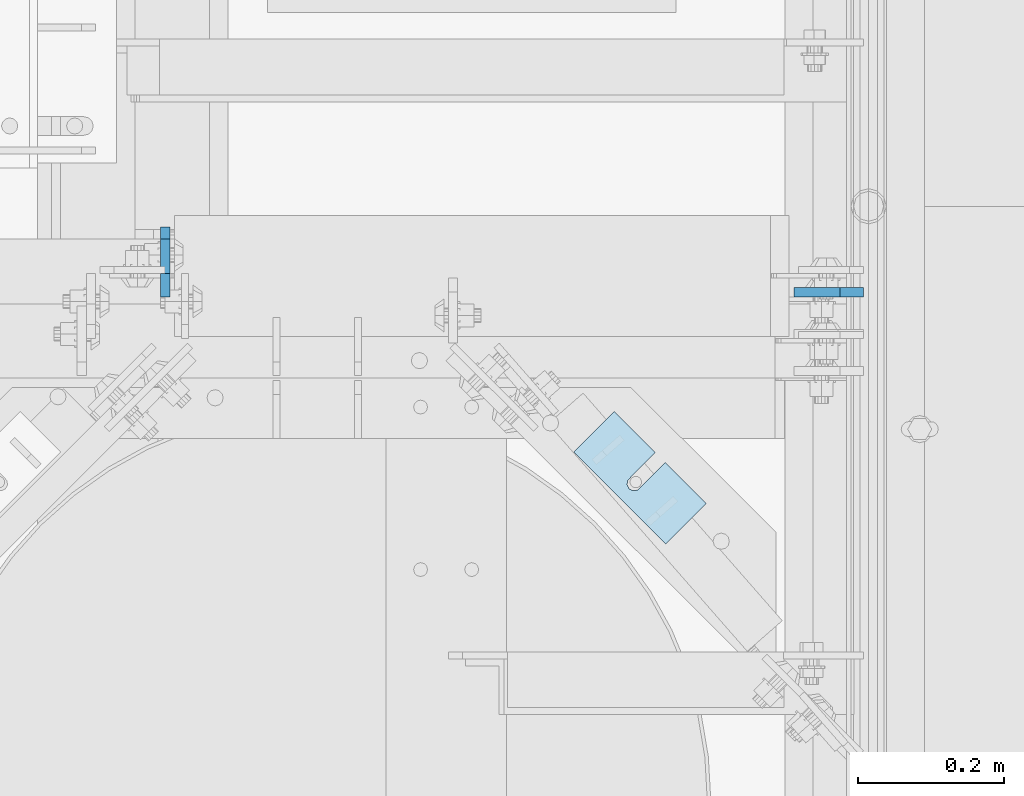
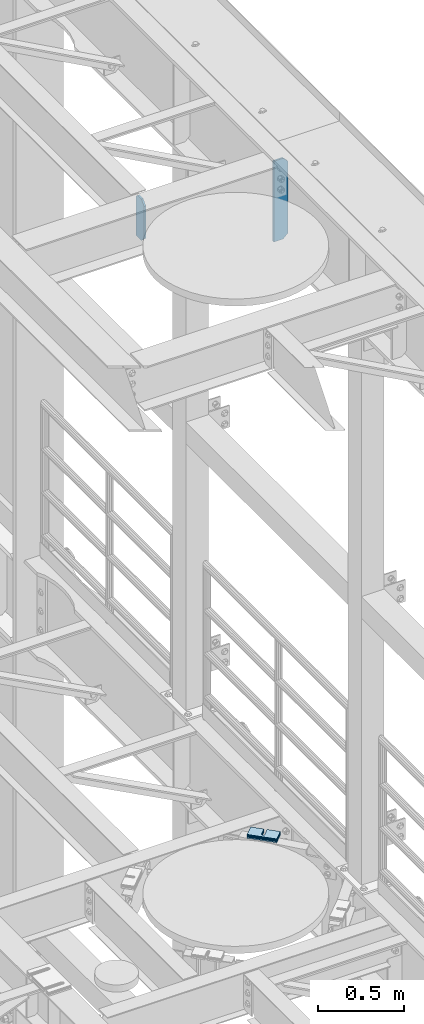
# One storey, part 1662 of 1876: 8 plates, 8 elements without a shape of their own.
"""IFC2X3 building model written with IfcOpenShell, lengths in millimetres."""

from ifc_helpers import new_model, si_unit, frame, origin_with_axes, place, context, subcontext, project, spatial, faceted_brep, material, type_object, element, aggregate, save


model = new_model("IFC2X3")

# Units and contexts
model_context = context("Model", 3, precision=1e-05, world=origin_with_axes())
body_context = subcontext(model_context, "Body", "Model", "MODEL_VIEW")
ifc_project = project(units=[si_unit("LENGTHUNIT", "METRE", prefix="MILLI"), si_unit("AREAUNIT", "SQUARE_METRE"), si_unit("VOLUMEUNIT", "CUBIC_METRE"), si_unit("MASSUNIT", "GRAM", prefix="KILO"), si_unit("TIMEUNIT", "SECOND"), si_unit("PLANEANGLEUNIT", "RADIAN"), si_unit("SOLIDANGLEUNIT", "STERADIAN"), si_unit("THERMODYNAMICTEMPERATUREUNIT", "DEGREE_CELSIUS"), si_unit("LUMINOUSINTENSITYUNIT", "LUMEN")], contexts=[model_context])

# Site, building, storey
site_placement = place(None, origin_with_axes())
site = spatial("IfcSite", under=ifc_project, at=site_placement, CompositionType="ELEMENT")
building_placement = place(site_placement, origin_with_axes())
building = spatial("IfcBuilding", under=site, at=building_placement, Name="Undefined", CompositionType="ELEMENT")
storey_placement = place(building_placement, origin_with_axes())
storey = spatial("IfcBuildingStorey", under=building, at=storey_placement, Name="Undefined", CompositionType="ELEMENT", Elevation=0.0)

# Assembly, plate
assembly_1_placement = place(storey_placement, origin_with_axes())
assembly_1 = element("IfcElementAssembly", 1, at=assembly_1_placement, inside=storey, Name="BEAM", AssemblyPlace="NOTDEFINED", PredefinedType="RIGID_FRAME")
ifc_material = material(Name="STEEL/A36")
plate_type_1 = type_object("IfcPlateType", PredefinedType="NOTDEFINED")
plate_1_placement = place(assembly_1_placement, frame((6657.97499990463, 4448.17420043945, 22255.1625), z_axis=(0.0, 0.0, 1.0), x_axis=(0.0, 1.0, 0.0)))
plate_1 = element("IfcPlate", 2, at=plate_1_placement, type_object=plate_type_1, material=ifc_material, Name="PLATE", context=body_context, shape_type="Brep", body=[
    faceted_brep([(0.0, -6.35000000000036, 258.762512207031), (31.75, -6.35000000000036, 290.512512207031), (31.75, 6.35000000000036, 290.512512207031), (0.0, 6.35000000000036, 258.762512207031), (0.0, -6.34999999999991, 31.75), (0.0, 6.34999999999991, 31.75), (31.75, -6.34999999999991, 0.0), (31.75, 6.34999999999991, 0.0), (95.25, -6.35000000000036, 0.0), (95.25, 6.35000000000036, 0.0), (95.25, -6.35000000000036, 274.637511908913), (79.3749874887271, -6.35000000000036, 290.512512207031), (79.3749874887271, 6.35000000000036, 290.512512207031), (95.25, 6.35000000000036, 274.637511908913)], [[[0, 1, 2, 3]], [[4, 0, 3, 5]], [[6, 4, 5, 7]], [[8, 6, 7, 9]], [[1, 0, 4, 6, 8, 10, 11]], [[2, 1, 11, 12]], [[9, 7, 5, 3, 2, 12, 13]], [[8, 9, 13, 10]], [[12, 11, 10, 13]]]),
])
aggregate(assembly_1, [plate_1])

assembly_2_placement = place(storey_placement, origin_with_axes())
assembly_2 = element("IfcElementAssembly", 3, at=assembly_2_placement, inside=storey, Name="BEAM", AssemblyPlace="NOTDEFINED", PredefinedType="RIGID_FRAME")
plate_2_placement = place(assembly_2_placement, frame((7612.85625, 4454.52420053482, 21959.8875), z_axis=(0.0, 0.0, 1.0), x_axis=(-1.0, 0.0, 0.0)))
plate_2 = element("IfcPlate", 4, at=plate_2_placement, type_object=plate_type_1, material=ifc_material, Name="PLATE", context=body_context, shape_type="Brep", body=[
    faceted_brep([(0.0, -6.34999999999991, 31.75), (0.0, -6.35000000000036, 538.162475585938), (0.0, 6.35000000000036, 538.162475585938), (0.0, 6.34999999999991, 31.75), (31.75, -6.35000000000036, 569.912475585938), (31.75, 6.35000000000036, 569.912475585938), (95.25, -6.35000000000036, 569.912475585938), (95.25, 6.35000000000036, 569.912475585938), (95.25, -6.35000000000036, 0.0), (95.25, 6.35000000000036, 0.0), (31.75, -6.34999999999991, 0.0), (31.75, 6.34999999999991, 0.0)], [[[0, 1, 2, 3]], [[1, 4, 5, 2]], [[4, 6, 7, 5]], [[6, 8, 9, 7]], [[8, 10, 11, 9]], [[10, 0, 3, 11]], [[5, 7, 9, 11, 3, 2]], [[10, 8, 6, 4, 1, 0]]]),
])
aggregate(assembly_2, [plate_2])

assembly_3_placement = place(storey_placement, origin_with_axes())
assembly_3 = element("IfcElementAssembly", 5, at=assembly_3_placement, inside=storey, Name="SHIM PLATE", AssemblyPlace="NOTDEFINED", PredefinedType="RIGID_FRAME")
plate_type_2 = type_object("IfcPlateType", PredefinedType="NOTDEFINED")
plate_3_placement = place(assembly_3_placement, frame((7397.85899402552, 4165.55524499807, 18009.3925), z_axis=(-0.707106066686189, -0.707107495686184, 0.0), x_axis=(-0.707107495686184, 0.707106066686189, 0.0)))
plate_3 = element("IfcPlate", 6, at=plate_3_placement, type_object=plate_type_2, material=ifc_material, Name="SHIM PLATE", context=body_context, shape_type="Brep", body=[
    faceted_brep([(79.3755953647978, -0.793499999999767, -3.63797880709171e-12), (79.3755953647978, 0.793499999999767, -3.63797880709171e-12), (79.3049756952778, 0.793499999999767, 47.6675290359176), (79.3049756952778, -0.793499999999767, 47.6675290359176), (79.4487723981229, 0.793499999999767, 53.7022829617508), (79.4487723981229, -0.793499999999767, 53.7022829617508), (83.063498120483, 0.793499999999767, 58.5368140030459), (83.063498120483, -0.793499999999767, 58.5368140030459), (88.8111609071966, 0.793499999999767, 60.3816188510955), (88.8111609071966, -0.793499999999767, 60.3816188510955), (94.5642614235203, 0.793499999999767, 58.5538423641483), (94.5642614235203, -0.793499999999767, 58.5538423641483), (98.3549540510812, -0.793499999999767, 47.6957349820686), (98.3549540510812, 0.793499999999767, 47.6957349820686), (98.4255737206086, 0.793499999999767, -5.00222085975111e-12), (98.4255737206086, -0.793499999999767, -5.00222085975111e-12), (98.1932875572447, -0.793499999999767, 53.7300366303029), (98.1932875572447, 0.793499999999767, 53.7300366303029), (9.09494701772928e-13, -0.793499999999767, 0.0), (7.93202807471971e-05, -0.793499999999767, 78.4900512695085), (7.93202807471971e-05, 0.793499999999767, 78.4900512695085), (9.09494701772928e-13, 0.793499999999767, 0.0), (177.801101684615, -0.793499999999767, 78.4900512695531), (177.801101684615, 0.793499999999767, 78.4900512695531), (177.801147461002, -0.793499999999767, -8.64019966684282e-12), (177.801147461002, 0.793499999999767, -8.64019966684282e-12)], [[[0, 1, 2, 3]], [[3, 2, 4, 5]], [[5, 4, 6, 7]], [[7, 6, 8, 9]], [[9, 8, 10, 11]], [[12, 13, 14, 15]], [[16, 17, 13, 12]], [[11, 10, 17, 16]], [[18, 19, 20, 21]], [[19, 22, 23, 20]], [[22, 24, 25, 23]], [[25, 24, 15, 14]], [[8, 6, 4, 2, 1, 21, 20, 23, 25, 14, 13, 17, 10]], [[18, 21, 1, 0]], [[15, 24, 22, 19, 18, 0, 3, 5, 7, 9, 11, 16, 12]]]),
])
aggregate(assembly_3, [plate_3])

assembly_4_placement = place(storey_placement, origin_with_axes())
assembly_4 = element("IfcElementAssembly", 7, at=assembly_4_placement, inside=storey, Name="SHIM PLATE", AssemblyPlace="NOTDEFINED", PredefinedType="RIGID_FRAME")
plate_type_3 = type_object("IfcPlateType", PredefinedType="NOTDEFINED")
plate_4_placement = place(assembly_4_placement, frame((7397.85899402552, 4165.55524499807, 18007.0115), z_axis=(-0.707106066686189, -0.707107495686184, 0.0), x_axis=(-0.707107495686184, 0.707106066686189, 0.0)))
plate_4 = element("IfcPlate", 8, at=plate_4_placement, type_object=plate_type_3, material=ifc_material, Name="SHIM PLATE", context=body_context, shape_type="Brep", body=[
    faceted_brep([(79.3755953647988, -1.58750000000146, -3.18323145620525e-12), (79.3755953647988, 1.58750000000146, -3.18323145620525e-12), (79.3049756952778, 1.58750000000146, 47.6675290359181), (79.3049756952778, -1.58750000000146, 47.6675290359181), (79.4487723981229, 1.58750000000146, 53.7022829617513), (79.4487723981229, -1.58750000000146, 53.7022829617513), (83.0634981204839, 1.58750000000146, 58.5368140030464), (83.0634981204839, -1.58750000000146, 58.5368140030464), (88.8111609071975, 1.58750000000146, 60.3816188510959), (88.8111609071975, -1.58750000000146, 60.3816188510959), (94.5642614235212, 1.58750000000146, 58.5538423641487), (94.5642614235212, -1.58750000000146, 58.5538423641487), (98.3549540510821, -1.58750000000146, 47.6957349820691), (98.3549540510821, 1.58750000000146, 47.6957349820691), (98.4255737206086, 1.58750000000146, -3.63797880709171e-12), (98.4255737206086, -1.58750000000146, -3.63797880709171e-12), (98.1932875572456, -1.58750000000146, 53.7300366303034), (98.1932875572456, 1.58750000000146, 53.7300366303034), (9.09494701772928e-13, -1.58750000000146, 4.54747350886464e-13), (7.93202807471971e-05, -1.58750000000146, 78.490051269509), (7.93202807471971e-05, 1.58750000000146, 78.490051269509), (9.09494701772928e-13, 1.58750000000146, 4.54747350886464e-13), (177.801101684615, -1.58750000000146, 78.4900512695535), (177.801101684615, 1.58750000000146, 78.4900512695535), (177.801147461002, -1.58750000000146, -8.18545231595635e-12), (177.801147461002, 1.58750000000146, -8.18545231595635e-12)], [[[0, 1, 2, 3]], [[3, 2, 4, 5]], [[5, 4, 6, 7]], [[7, 6, 8, 9]], [[9, 8, 10, 11]], [[12, 13, 14, 15]], [[16, 17, 13, 12]], [[11, 10, 17, 16]], [[18, 19, 20, 21]], [[19, 22, 23, 20]], [[22, 24, 25, 23]], [[25, 24, 15, 14]], [[8, 6, 4, 2, 1, 21, 20, 23, 25, 14, 13, 17, 10]], [[18, 21, 1, 0]], [[15, 24, 22, 19, 18, 0, 3, 5, 7, 9, 11, 16, 12]]]),
])
aggregate(assembly_4, [plate_4])

assembly_5_placement = place(storey_placement, origin_with_axes())
assembly_5 = element("IfcElementAssembly", 9, at=assembly_5_placement, inside=storey, Name="SHIM PLATE", AssemblyPlace="NOTDEFINED", PredefinedType="RIGID_FRAME")
plate_5_placement = place(assembly_5_placement, frame((7397.85899402552, 4165.55524499807, 18003.8365), z_axis=(-0.707106066686189, -0.707107495686184, 0.0), x_axis=(-0.707107495686184, 0.707106066686189, 0.0)))
plate_5 = element("IfcPlate", 10, at=plate_5_placement, type_object=plate_type_3, material=ifc_material, Name="SHIM PLATE", context=body_context, shape_type="Brep", body=[
    faceted_brep([(79.3755953647988, -1.58750000000146, -3.18323145620525e-12), (79.3755953647988, 1.58750000000146, -3.18323145620525e-12), (79.3049756952778, 1.58750000000146, 47.6675290359181), (79.3049756952778, -1.58750000000146, 47.6675290359181), (79.4487723981229, 1.58750000000146, 53.7022829617513), (79.4487723981229, -1.58750000000146, 53.7022829617513), (83.0634981204839, 1.58750000000146, 58.5368140030464), (83.0634981204839, -1.58750000000146, 58.5368140030464), (88.8111609071975, 1.58750000000146, 60.3816188510959), (88.8111609071975, -1.58750000000146, 60.3816188510959), (94.5642614235212, 1.58750000000146, 58.5538423641487), (94.5642614235212, -1.58750000000146, 58.5538423641487), (98.3549540510821, -1.58750000000146, 47.6957349820691), (98.3549540510821, 1.58750000000146, 47.6957349820691), (98.4255737206086, 1.58750000000146, -3.63797880709171e-12), (98.4255737206086, -1.58750000000146, -3.63797880709171e-12), (98.1932875572456, -1.58750000000146, 53.7300366303034), (98.1932875572456, 1.58750000000146, 53.7300366303034), (9.09494701772928e-13, -1.58750000000146, 4.54747350886464e-13), (7.93202807471971e-05, -1.58750000000146, 78.490051269509), (7.93202807471971e-05, 1.58750000000146, 78.490051269509), (9.09494701772928e-13, 1.58750000000146, 4.54747350886464e-13), (177.801101684615, -1.58750000000146, 78.4900512695535), (177.801101684615, 1.58750000000146, 78.4900512695535), (177.801147461002, -1.58750000000146, -8.18545231595635e-12), (177.801147461002, 1.58750000000146, -8.18545231595635e-12)], [[[0, 1, 2, 3]], [[3, 2, 4, 5]], [[5, 4, 6, 7]], [[7, 6, 8, 9]], [[9, 8, 10, 11]], [[12, 13, 14, 15]], [[16, 17, 13, 12]], [[11, 10, 17, 16]], [[18, 19, 20, 21]], [[19, 22, 23, 20]], [[22, 24, 25, 23]], [[25, 24, 15, 14]], [[8, 6, 4, 2, 1, 21, 20, 23, 25, 14, 13, 17, 10]], [[18, 21, 1, 0]], [[15, 24, 22, 19, 18, 0, 3, 5, 7, 9, 11, 16, 12]]]),
])
aggregate(assembly_5, [plate_5])

assembly_6_placement = place(storey_placement, origin_with_axes())
assembly_6 = element("IfcElementAssembly", 11, at=assembly_6_placement, inside=storey, Name="SHIM PLATE", AssemblyPlace="NOTDEFINED", PredefinedType="RIGID_FRAME")
plate_type_4 = type_object("IfcPlateType", PredefinedType="NOTDEFINED")
plate_6_placement = place(assembly_6_placement, frame((7397.85899402552, 4165.55524499807, 17999.868), z_axis=(-0.707106066686189, -0.707107495686184, 0.0), x_axis=(-0.707107495686184, 0.707106066686189, 0.0)))
plate_6 = element("IfcPlate", 12, at=plate_6_placement, type_object=plate_type_4, material=ifc_material, Name="SHIM PLATE", context=body_context, shape_type="Brep", body=[
    faceted_brep([(79.3755953647969, -2.38100000000122, -3.18323145620525e-12), (79.3755953647969, 2.38100000000122, -3.18323145620525e-12), (79.3049756952778, 2.38100000000122, 47.6675290359181), (79.3049756952778, -2.38100000000122, 47.6675290359181), (79.4487723981229, 2.38100000000122, 53.7022829617513), (79.4487723981229, -2.38100000000122, 53.7022829617513), (83.063498120483, 2.38100000000122, 58.5368140030464), (83.063498120483, -2.38100000000122, 58.5368140030464), (88.8111609071966, 2.38100000000122, 60.3816188510959), (88.8111609071966, -2.38100000000122, 60.3816188510959), (94.5642614235203, 2.38100000000122, 58.5538423641487), (94.5642614235203, -2.38100000000122, 58.5538423641487), (98.3549540510821, -2.38100000000122, 47.6957349820691), (98.3549540510821, 2.38100000000122, 47.6957349820691), (98.4255737206086, 2.38100000000122, -4.54747350886464e-12), (98.4255737206086, -2.38100000000122, -4.54747350886464e-12), (98.1932875572447, -2.38100000000122, 53.7300366303034), (98.1932875572447, 2.38100000000122, 53.7300366303034), (0.0, -2.38100000000122, 4.54747350886464e-13), (7.93202807471971e-05, -2.38100000000122, 78.4900512695094), (7.93202807471971e-05, 2.38100000000122, 78.4900512695094), (0.0, 2.38100000000122, 4.54747350886464e-13), (177.801101684615, -2.38100000000122, 78.4900512695526), (177.801101684615, 2.38100000000122, 78.4900512695526), (177.801147461, -2.38100000000122, -7.73070496506989e-12), (177.801147461, 2.38100000000122, -7.73070496506989e-12)], [[[0, 1, 2, 3]], [[3, 2, 4, 5]], [[5, 4, 6, 7]], [[7, 6, 8, 9]], [[9, 8, 10, 11]], [[12, 13, 14, 15]], [[16, 17, 13, 12]], [[11, 10, 17, 16]], [[18, 19, 20, 21]], [[19, 22, 23, 20]], [[22, 24, 25, 23]], [[25, 24, 15, 14]], [[8, 6, 4, 2, 1, 21, 20, 23, 25, 14, 13, 17, 10]], [[18, 21, 1, 0]], [[15, 24, 22, 19, 18, 0, 3, 5, 7, 9, 11, 16, 12]]]),
])
aggregate(assembly_6, [plate_6])

assembly_7_placement = place(storey_placement, origin_with_axes())
assembly_7 = element("IfcElementAssembly", 13, at=assembly_7_placement, inside=storey, Name="SHIM PLATE", AssemblyPlace="NOTDEFINED", PredefinedType="RIGID_FRAME")
plate_7_placement = place(assembly_7_placement, frame((7397.85899402552, 4165.55524499807, 17995.106), z_axis=(-0.707106066686189, -0.707107495686184, 0.0), x_axis=(-0.707107495686184, 0.707106066686189, 0.0)))
plate_7 = element("IfcPlate", 14, at=plate_7_placement, type_object=plate_type_4, material=ifc_material, Name="SHIM PLATE", context=body_context, shape_type="Brep", body=[
    faceted_brep([(79.3755953647969, -2.38100000000122, -3.18323145620525e-12), (79.3755953647969, 2.38100000000122, -3.18323145620525e-12), (79.3049756952778, 2.38100000000122, 47.6675290359181), (79.3049756952778, -2.38100000000122, 47.6675290359181), (79.4487723981229, 2.38100000000122, 53.7022829617513), (79.4487723981229, -2.38100000000122, 53.7022829617513), (83.063498120483, 2.38100000000122, 58.5368140030464), (83.063498120483, -2.38100000000122, 58.5368140030464), (88.8111609071966, 2.38100000000122, 60.3816188510959), (88.8111609071966, -2.38100000000122, 60.3816188510959), (94.5642614235203, 2.38100000000122, 58.5538423641487), (94.5642614235203, -2.38100000000122, 58.5538423641487), (98.3549540510821, -2.38100000000122, 47.6957349820691), (98.3549540510821, 2.38100000000122, 47.6957349820691), (98.4255737206086, 2.38100000000122, -4.54747350886464e-12), (98.4255737206086, -2.38100000000122, -4.54747350886464e-12), (98.1932875572447, -2.38100000000122, 53.7300366303034), (98.1932875572447, 2.38100000000122, 53.7300366303034), (0.0, -2.38100000000122, 4.54747350886464e-13), (7.93202807471971e-05, -2.38100000000122, 78.4900512695094), (7.93202807471971e-05, 2.38100000000122, 78.4900512695094), (0.0, 2.38100000000122, 4.54747350886464e-13), (177.801101684615, -2.38100000000122, 78.4900512695526), (177.801101684615, 2.38100000000122, 78.4900512695526), (177.801147461, -2.38100000000122, -7.73070496506989e-12), (177.801147461, 2.38100000000122, -7.73070496506989e-12)], [[[0, 1, 2, 3]], [[3, 2, 4, 5]], [[5, 4, 6, 7]], [[7, 6, 8, 9]], [[9, 8, 10, 11]], [[12, 13, 14, 15]], [[16, 17, 13, 12]], [[11, 10, 17, 16]], [[18, 19, 20, 21]], [[19, 22, 23, 20]], [[22, 24, 25, 23]], [[25, 24, 15, 14]], [[8, 6, 4, 2, 1, 21, 20, 23, 25, 14, 13, 17, 10]], [[18, 21, 1, 0]], [[15, 24, 22, 19, 18, 0, 3, 5, 7, 9, 11, 16, 12]]]),
])
aggregate(assembly_7, [plate_7])

assembly_8_placement = place(storey_placement, origin_with_axes())
assembly_8 = element("IfcElementAssembly", 15, at=assembly_8_placement, inside=storey, Name="SHIM PLATE", AssemblyPlace="NOTDEFINED", PredefinedType="RIGID_FRAME")
plate_type_5 = type_object("IfcPlateType", PredefinedType="NOTDEFINED")
plate_8_placement = place(assembly_8_placement, frame((7397.85899402552, 4165.55524499807, 17987.9625), z_axis=(-0.707106066686189, -0.707107495686184, 0.0), x_axis=(-0.707107495686184, 0.707106066686189, 0.0)))
plate_8 = element("IfcPlate", 16, at=plate_8_placement, type_object=plate_type_5, material=ifc_material, Name="SHIM PLATE", context=body_context, shape_type="Brep", body=[
    faceted_brep([(79.3755953647978, -4.76250000000073, -2.27373675443232e-12), (79.3755953647978, 4.76250000000073, -2.27373675443232e-12), (79.3049756952787, 4.76250000000073, 47.6675290359171), (79.3049756952787, -4.76250000000073, 47.6675290359171), (79.4487723981238, 4.76250000000073, 53.7022829617517), (79.4487723981238, -4.76250000000073, 53.7022829617517), (83.0634981204839, 4.76250000000073, 58.5368140030459), (83.0634981204839, -4.76250000000073, 58.5368140030459), (88.8111609071975, 4.76250000000073, 60.3816188510955), (88.8111609071975, -4.76250000000073, 60.3816188510955), (94.5642614235203, 4.76250000000073, 58.5538423641483), (94.5642614235203, -4.76250000000073, 58.5538423641483), (98.354954051083, -4.76250000000073, 47.6957349820682), (98.354954051083, 4.76250000000073, 47.6957349820682), (98.4255737206076, 4.76250000000073, -2.27373675443232e-12), (98.4255737206076, -4.76250000000073, -2.27373675443232e-12), (98.1932875572456, -4.76250000000073, 53.7300366303025), (98.1932875572456, 4.76250000000073, 53.7300366303025), (0.0, -4.76249999999982, 0.0), (7.93202807471971e-05, -4.76250000000073, 78.4900512695085), (7.93202807471971e-05, 4.76250000000073, 78.4900512695085), (0.0, 4.76249999999982, 0.0), (177.801101684615, -4.76250000000073, 78.4900512695531), (177.801101684615, 4.76250000000073, 78.4900512695531), (177.801147461001, -4.76250000000073, -5.00222085975111e-12), (177.801147461001, 4.76250000000073, -5.00222085975111e-12)], [[[0, 1, 2, 3]], [[3, 2, 4, 5]], [[5, 4, 6, 7]], [[7, 6, 8, 9]], [[9, 8, 10, 11]], [[12, 13, 14, 15]], [[16, 17, 13, 12]], [[11, 10, 17, 16]], [[18, 19, 20, 21]], [[19, 22, 23, 20]], [[22, 24, 25, 23]], [[25, 24, 15, 14]], [[8, 6, 4, 2, 1, 21, 20, 23, 25, 14, 13, 17, 10]], [[18, 21, 1, 0]], [[15, 24, 22, 19, 18, 0, 3, 5, 7, 9, 11, 16, 12]]]),
])
aggregate(assembly_8, [plate_8])

save(model, "model.ifc")
